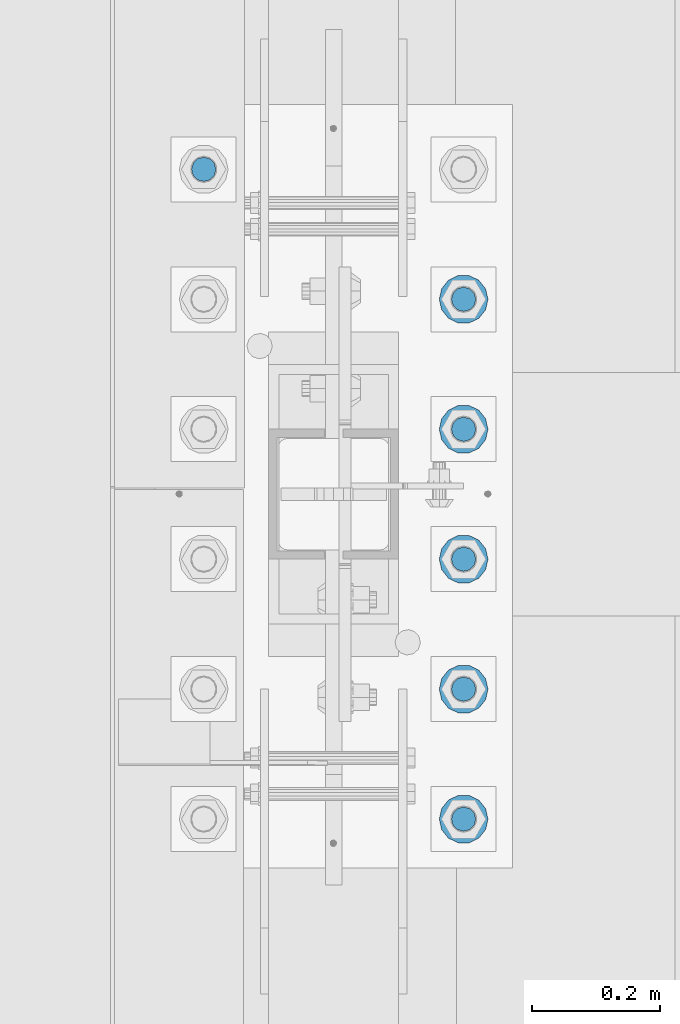
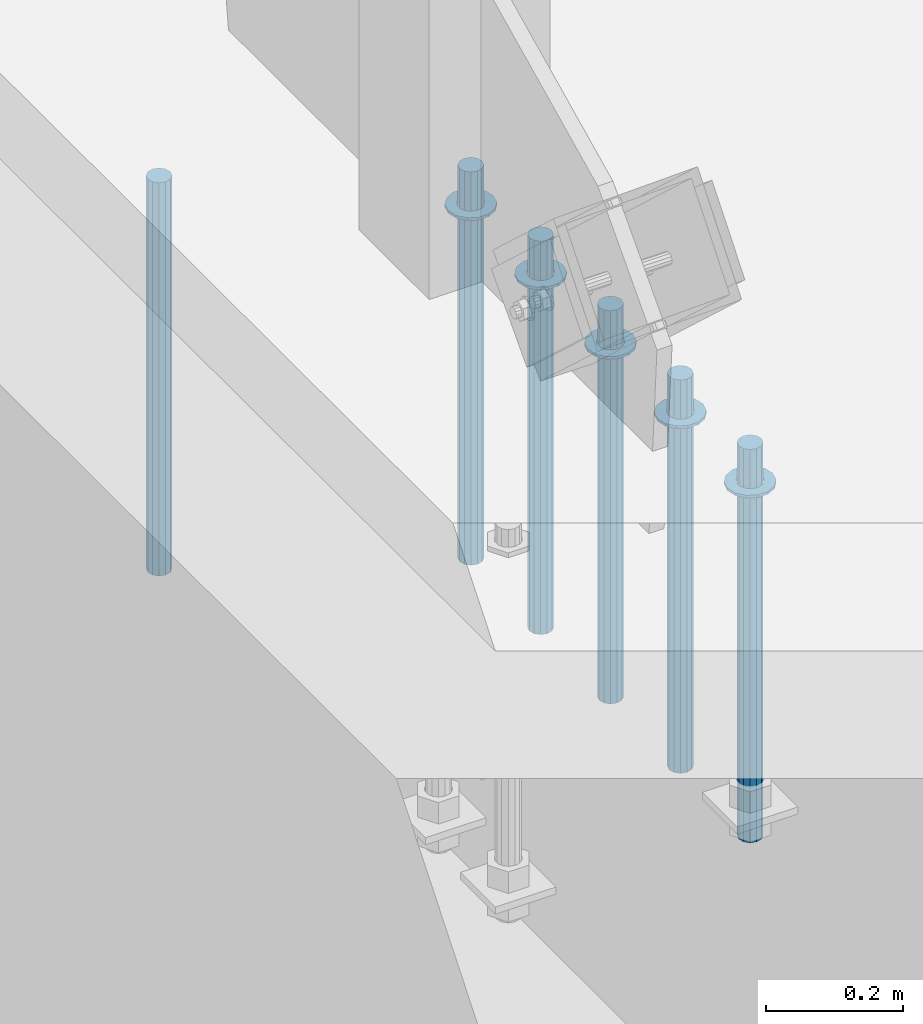
# One storey, part 924 of 1763: 11 columns, 1 element without a shape of its own.
"""IFC2X3 building model written with IfcOpenShell, lengths in millimetres."""

import ifcopenshell
import ifcopenshell.guid

model = None  # the IFC model being written
_history = None  # IfcOwnerHistory: only IFC2X3 demands one
_inside = {}  # id of a spatial element -> (the spatial element, [elements in it])
_under = {}  # id of a project, library or spatial element -> (it, [spatial elements below it])
_declared = {}  # id of a project -> (the project, [libraries it declares])
_typed = {}  # id of a type object -> (the type object, [elements of that type])
_made_of = {}  # id of a material, layer set ... -> (it, [elements and type objects made of it])


def new_model(schema):
    """Start an empty IFC model of exactly this schema.

    Asked for "IFC4X3", IfcOpenShell would pick the latest addendum, in which some entities
    have other attributes; the version numbers below select the first issue.
    IFC2X3 requires an IfcOwnerHistory on every rooted entity: one is made here for all.
    """
    global model, _history
    if schema == "IFC4X3":
        model = ifcopenshell.file(schema_version=(4, 3, 0, 0))
    else:
        model = ifcopenshell.file(schema=schema)
    _inside.clear()
    _under.clear()
    _declared.clear()
    _typed.clear()
    _made_of.clear()
    _history = None
    if model.schema == "IFC2X3":
        org = make("IfcOrganization", Name="unknown")
        user = make(
            "IfcPersonAndOrganization",
            ThePerson=make("IfcPerson", FamilyName="unknown"),
            TheOrganization=org,
        )
        app = make(
            "IfcApplication",
            ApplicationDeveloper=org,
            Version="unknown",
            ApplicationFullName="unknown",
            ApplicationIdentifier="unknown",
        )
        _history = make(
            "IfcOwnerHistory",
            OwningUser=user,
            OwningApplication=app,
            ChangeAction="ADDED",
            CreationDate=0,
        )
    return model


def make(cls, **values):
    """One entity of the class cls with the attributes given. An attribute that is None is left unset."""
    return model.create_entity(
        cls, **{name: value for name, value in values.items() if value is not None}
    )


def rooted(cls, **values):
    """An entity with a GlobalId (a new one), such as an element, a storey or a relation."""
    return make(cls, GlobalId=ifcopenshell.guid.new(), OwnerHistory=_history, **values)


def si_unit(unit_type, name, prefix=None):
    """IfcSIUnit, for example si_unit("LENGTHUNIT", "METRE", prefix="MILLI")."""
    return make("IfcSIUnit", UnitType=unit_type, Prefix=prefix, Name=name)


def assignment(units):
    """IfcUnitAssignment: the units of a project."""
    return None if units is None else make("IfcUnitAssignment", Units=units)


def point(xyz):
    """IfcCartesianPoint."""
    return None if xyz is None else make("IfcCartesianPoint", Coordinates=xyz)


def direction(xyz):
    """IfcDirection."""
    return None if xyz is None else make("IfcDirection", DirectionRatios=xyz)


def frame(location, z_axis=None, x_axis=None):
    """IfcAxis2Placement3D, a coordinate frame: its origin and axes. An axis left out is left unset."""
    return make(
        "IfcAxis2Placement3D",
        Location=point(location),
        Axis=direction(z_axis),
        RefDirection=direction(x_axis),
    )


def origin_with_axes():
    """The frame at (0, 0, 0) with the z axis (0, 0, 1) and the x axis (1, 0, 0) written out."""
    return frame((0.0, 0.0, 0.0), z_axis=(0.0, 0.0, 1.0), x_axis=(1.0, 0.0, 0.0))


def place(relative_to, where):
    """IfcLocalPlacement: puts the frame where relative to a parent placement (None: the world)."""
    return make(
        "IfcLocalPlacement", PlacementRelTo=relative_to, RelativePlacement=where
    )


def context(
    kind, dimensions, precision=None, world=None, true_north=None, identifier=None
):
    """IfcGeometricRepresentationContext, for example the 3D "Model" context."""
    return make(
        "IfcGeometricRepresentationContext",
        ContextIdentifier=identifier,
        ContextType=kind,
        CoordinateSpaceDimension=dimensions,
        Precision=precision,
        WorldCoordinateSystem=world,
        TrueNorth=true_north,
    )


def subcontext(parent, identifier, kind, view, scale=None):
    """IfcGeometricRepresentationSubContext, for example "Body" below "Model"."""
    return make(
        "IfcGeometricRepresentationSubContext",
        ContextIdentifier=identifier,
        ContextType=kind,
        ParentContext=parent,
        TargetScale=scale,
        TargetView=view,
    )


def project(units=None, contexts=None):
    """IfcProject with its units and contexts."""
    return rooted(
        "IfcProject",
        Name="project",
        RepresentationContexts=contexts,
        UnitsInContext=assignment(units),
    )


def spatial(cls, under=None, at=None, **own):
    """A site, building, storey or space (cls), placed at a placement, below another one or the project."""
    s = rooted(cls, ObjectPlacement=at, **own)
    if under is not None:
        _under.setdefault(under.id(), (under, []))[1].append(s)
    return s


def faces_of(points, faces, orient=None, outer=None):
    """IfcFace entities. A face is a list of loops; a loop is a list of indices into points, from 0.

    orient and outer hold one flag for each loop. By default every Orientation is true, the
    first loop of a face is its IfcFaceOuterBound and the others are IfcFaceBound.
    """
    made = []
    for i, loops in enumerate(faces):
        bounds = []
        for j, loop in enumerate(loops):
            is_outer = j == 0 if outer is None else outer[i][j]
            bounds.append(
                make(
                    "IfcFaceOuterBound" if is_outer else "IfcFaceBound",
                    Bound=make("IfcPolyLoop", Polygon=[points[k] for k in loop]),
                    Orientation=True if orient is None else orient[i][j],
                )
            )
        made.append(make("IfcFace", Bounds=bounds))
    return made


def faceted_brep(points, faces, orient=None, outer=None, voids=None):
    """IfcFacetedBrep: a solid bounded by flat faces; with voids (closed shells), ...WithVoids."""
    shared = [point(p) for p in points]
    hull = make("IfcClosedShell", CfsFaces=faces_of(shared, faces, orient, outer))
    if voids is None:
        return make("IfcFacetedBrep", Outer=hull)
    return make(
        "IfcFacetedBrepWithVoids",
        Outer=hull,
        Voids=[
            make(cls, CfsFaces=faces_of(shared, fs, o, b)) for cls, fs, o, b in voids
        ],
    )


def shape(context_of_items, identifier, shape_type, items):
    """IfcShapeRepresentation: the items that make up one representation, for example the "Body"."""
    return make(
        "IfcShapeRepresentation",
        ContextOfItems=context_of_items,
        RepresentationIdentifier=identifier,
        RepresentationType=shape_type,
        Items=items,
    )


def material(Name=None, Category=None):
    """IfcMaterial."""
    return make("IfcMaterial", Name=Name, Category=Category)


def made_of(thing, what):
    """Note that an element or type object is made of a material, layer set ...; save() writes the relation."""
    if what is not None:
        _made_of.setdefault(what.id(), (what, []))[1].append(thing)
    return thing


def type_object(cls, material=None, **own):
    """A type object (cls), such as IfcWallType, which elements share."""
    return made_of(rooted(cls, **own), material)


def element(
    cls,
    number,
    at=None,
    inside=None,
    cuts=None,
    type_object=None,
    material=None,
    context=None,
    identifier="Body",
    shape_type=None,
    held_by="IfcProductDefinitionShape",
    body=None,
    shapes=None,
    **own,
):
    """One element of the class cls, such as IfcWall. Its Tag is "e" and its number.

    at: its placement. inside: the storey or other place that contains it. cuts: it is an
    opening in that element (IfcRelVoidsElement). A single representation is given by context,
    identifier, shape_type and body (its items); several are given by shapes. held_by: the class
    of the entity that holds the representations. save() writes the other relations.
    """
    e = rooted(cls, Tag="e%d" % number, ObjectPlacement=at, **own)
    if body is not None:
        shapes = [shape(context, identifier, shape_type, body)]
    if shapes is not None:
        e.Representation = make(held_by, Representations=shapes)
    if inside is not None:
        _inside.setdefault(inside.id(), (inside, []))[1].append(e)
    if cuts is not None:
        rooted(
            "IfcRelVoidsElement", RelatingBuildingElement=cuts, RelatedOpeningElement=e
        )
    if type_object is not None:
        _typed.setdefault(type_object.id(), (type_object, []))[1].append(e)
    return made_of(e, material)


def aggregate(whole, parts):
    """IfcRelAggregates: a whole, such as a stair, and the parts it consists of."""
    return rooted("IfcRelAggregates", RelatingObject=whole, RelatedObjects=parts)


def save(model, path):
    """Write the relations noted so far, then the file.

    IfcRelAggregates (storeys below a building ...), IfcRelContainedInSpatialStructure (elements
    in a storey), IfcRelDefinesByType, IfcRelAssociatesMaterial and IfcRelDeclares: one each for
    every whole, place, type object, material and project.
    """
    for whole, parts in _under.values():
        aggregate(whole, parts)
    for where, things in _inside.values():
        rooted(
            "IfcRelContainedInSpatialStructure",
            RelatedElements=things,
            RelatingStructure=where,
        )
    for kind, things in _typed.values():
        rooted("IfcRelDefinesByType", RelatedObjects=things, RelatingType=kind)
    for what, things in _made_of.values():
        rooted("IfcRelAssociatesMaterial", RelatedObjects=things, RelatingMaterial=what)
    for by, libraries in _declared.values():
        rooted("IfcRelDeclares", RelatingContext=by, RelatedDefinitions=libraries)
    model.write(path)


model = new_model("IFC2X3")

# Units and contexts
model_context = context("Model", 3, precision=1e-05, world=origin_with_axes())
body_context = subcontext(model_context, "Body", "Model", "MODEL_VIEW")
ifc_project = project(units=[si_unit("LENGTHUNIT", "METRE", prefix="MILLI"), si_unit("AREAUNIT", "SQUARE_METRE"), si_unit("VOLUMEUNIT", "CUBIC_METRE"), si_unit("MASSUNIT", "GRAM", prefix="KILO"), si_unit("TIMEUNIT", "SECOND"), si_unit("PLANEANGLEUNIT", "RADIAN"), si_unit("SOLIDANGLEUNIT", "STERADIAN"), si_unit("THERMODYNAMICTEMPERATUREUNIT", "DEGREE_CELSIUS"), si_unit("LUMINOUSINTENSITYUNIT", "LUMEN")], contexts=[model_context])

# Site, building, storey
site_placement = place(None, origin_with_axes())
site = spatial("IfcSite", under=ifc_project, at=site_placement, CompositionType="ELEMENT")
building_placement = place(site_placement, origin_with_axes())
building = spatial("IfcBuilding", under=site, at=building_placement, Name="Undefined", CompositionType="ELEMENT")
storey_placement = place(building_placement, origin_with_axes())
storey = spatial("IfcBuildingStorey", under=building, at=storey_placement, Name="Undefined", CompositionType="ELEMENT", Elevation=0.0)

# Assembly, columns
assembly_placement = place(storey_placement, origin_with_axes())
assembly = element("IfcElementAssembly", 1, at=assembly_placement, inside=storey, Name="TEMPLATE", AssemblyPlace="NOTDEFINED", PredefinedType="RIGID_FRAME")
ifc_material_1 = material(Name="STEEL/F436")
column_type_1 = type_object("IfcColumnType", Name="1-1/2_WASHER", PredefinedType="NOTDEFINED")
column_1_placement = place(assembly_placement, frame((-87172.2372736984, -50.7999999999992, 5151.4375), z_axis=(0.0, 1.0, 0.0), x_axis=(0.0, 0.0, -1.0)))
column_1 = element("IfcColumn", 2, at=column_1_placement, type_object=column_type_1, material=ifc_material_1, Name="WASHER", ObjectType="1-1/2_WASHER", context=body_context, shape_type="Brep", body=[
    faceted_brep([(0.0, -38.0999984741211, 0.0), (0.0, -34.3269124923099, -16.5309697983248), (4.76249999999982, -34.3269124923099, -16.5309697983248), (4.76249999999982, -38.0999984741211, 0.0), (0.0, -23.7549604994492, -29.7877782890519), (4.76249999999982, -23.7549604994492, -29.7877782890519), (0.0, -8.47804724419257, -37.1447519665053), (4.76249999999982, -8.47804724419257, -37.1447519665053), (0.0, 8.47804724419257, -37.1447519665053), (4.76249999999982, 8.47804724419257, -37.1447519665053), (0.0, 23.7549604994492, -29.7877782890519), (4.76249999999982, 23.7549604994492, -29.7877782890519), (0.0, 34.3269124923099, -16.5309697983248), (4.76249999999982, 34.3269124923099, -16.5309697983248), (0.0, 38.0999984741211, 0.0), (4.76249999999982, 38.0999984741211, 0.0), (0.0, 34.3269124923099, 16.5309697983248), (4.76249999999982, 34.3269124923099, 16.5309697983248), (0.0, 23.7549604994492, 29.7877782890519), (4.76249999999982, 23.7549604994492, 29.7877782890519), (0.0, 8.47804724419257, 37.1447519665053), (4.76249999999982, 8.47804724419257, 37.1447519665053), (0.0, -8.47804724419257, 37.1447519665053), (4.76249999999982, -8.47804724419257, 37.1447519665053), (0.0, -23.7549604994492, 29.7877782890519), (4.76249999999982, -23.7549604994492, 29.7877782890519), (0.0, -34.3269124923099, 16.5309697983248), (4.76249999999982, -34.3269124923099, 16.5309697983248), (0.0, 0.0, 20.6399993896484), (0.0, 8.95536011056538, 18.5959968835978), (4.76249999999982, 8.95536011056538, 18.5959968835978), (4.76249999999982, 0.0, 20.6399993896484), (0.0, 16.1370013209453, 12.8688291298167), (4.76249999999982, 16.1370013209453, 12.8688291298167), (0.0, 20.1225115123816, 4.59283194104137), (4.76249999999982, 20.1225115123816, 4.59283194104137), (0.0, 20.1225115123816, -4.59283194104319), (4.76249999999982, 20.1225115123816, -4.59283194104319), (0.0, 16.1370013209453, -12.8688291298167), (4.76249999999982, 16.1370013209453, -12.8688291298167), (0.0, 8.95536011056538, -18.5959968835978), (4.76249999999982, 8.95536011056538, -18.5959968835978), (0.0, 0.0, -20.6399993896484), (4.76249999999982, 0.0, -20.6399993896484), (0.0, -8.95536011056538, -18.5959968835978), (4.76249999999982, -8.95536011056538, -18.5959968835978), (0.0, -16.1370013209453, -12.8688291298167), (4.76249999999982, -16.1370013209453, -12.8688291298167), (0.0, -20.1225115123816, -4.59283194104137), (4.76249999999982, -20.1225115123816, -4.59283194104137), (0.0, -20.1225115123816, 4.59283194104319), (4.76249999999982, -20.1225115123816, 4.59283194104319), (0.0, -16.1370013209453, 12.8688291298167), (4.76249999999982, -16.1370013209453, 12.8688291298167), (0.0, -8.95536011056538, 18.5959968835978), (4.76249999999982, -8.95536011056538, 18.5959968835978)], [[[0, 1, 2, 3]], [[1, 4, 5, 2]], [[4, 6, 7, 5]], [[6, 8, 9, 7]], [[8, 10, 11, 9]], [[10, 12, 13, 11]], [[12, 14, 15, 13]], [[14, 16, 17, 15]], [[16, 18, 19, 17]], [[18, 20, 21, 19]], [[20, 22, 23, 21]], [[22, 24, 25, 23]], [[24, 26, 27, 25]], [[26, 0, 3, 27]], [[28, 29, 30, 31]], [[29, 32, 33, 30]], [[32, 34, 35, 33]], [[34, 36, 37, 35]], [[36, 38, 39, 37]], [[38, 40, 41, 39]], [[40, 42, 43, 41]], [[42, 44, 45, 43]], [[44, 46, 47, 45]], [[46, 48, 49, 47]], [[48, 50, 51, 49]], [[50, 52, 53, 51]], [[52, 54, 55, 53]], [[54, 28, 31, 55]], [[5, 7, 9, 11, 13, 15, 17, 19, 21, 23, 25, 27, 3, 2], [33, 35, 37, 39, 41, 43, 45, 47, 49, 51, 53, 55, 31, 30]], [[26, 24, 22, 20, 18, 16, 14, 12, 10, 8, 6, 4, 1, 0], [54, 52, 50, 48, 46, 44, 42, 40, 38, 36, 34, 32, 29, 28]]]),
])
column_2_placement = place(assembly_placement, frame((-87172.2372736984, 152.400000000001, 5151.4375), z_axis=(0.0, 1.0, 0.0), x_axis=(0.0, 0.0, -1.0)))
column_2 = element("IfcColumn", 3, at=column_2_placement, type_object=column_type_1, material=ifc_material_1, Name="WASHER", ObjectType="1-1/2_WASHER", context=body_context, shape_type="Brep", body=[
    faceted_brep([(0.0, -38.0999984741211, 0.0), (0.0, -34.3269124923099, -16.5309697983248), (4.76249999999982, -34.3269124923099, -16.5309697983248), (4.76249999999982, -38.0999984741211, 0.0), (0.0, -23.7549604994492, -29.7877782890519), (4.76249999999982, -23.7549604994492, -29.7877782890519), (0.0, -8.47804724419257, -37.1447519665053), (4.76249999999982, -8.47804724419257, -37.1447519665053), (0.0, 8.47804724419257, -37.1447519665053), (4.76249999999982, 8.47804724419257, -37.1447519665053), (0.0, 23.7549604994492, -29.7877782890519), (4.76249999999982, 23.7549604994492, -29.7877782890519), (0.0, 34.3269124923099, -16.5309697983248), (4.76249999999982, 34.3269124923099, -16.5309697983248), (0.0, 38.0999984741211, 0.0), (4.76249999999982, 38.0999984741211, 0.0), (0.0, 34.3269124923099, 16.5309697983248), (4.76249999999982, 34.3269124923099, 16.5309697983248), (0.0, 23.7549604994492, 29.7877782890519), (4.76249999999982, 23.7549604994492, 29.7877782890519), (0.0, 8.47804724419257, 37.1447519665053), (4.76249999999982, 8.47804724419257, 37.1447519665053), (0.0, -8.47804724419257, 37.1447519665053), (4.76249999999982, -8.47804724419257, 37.1447519665053), (0.0, -23.7549604994492, 29.7877782890519), (4.76249999999982, -23.7549604994492, 29.7877782890519), (0.0, -34.3269124923099, 16.5309697983248), (4.76249999999982, -34.3269124923099, 16.5309697983248), (0.0, 0.0, 20.6399993896484), (0.0, 8.95536011056538, 18.5959968835978), (4.76249999999982, 8.95536011056538, 18.5959968835978), (4.76249999999982, 0.0, 20.6399993896484), (0.0, 16.1370013209453, 12.8688291298167), (4.76249999999982, 16.1370013209453, 12.8688291298167), (0.0, 20.1225115123816, 4.59283194104137), (4.76249999999982, 20.1225115123816, 4.59283194104137), (0.0, 20.1225115123816, -4.59283194104319), (4.76249999999982, 20.1225115123816, -4.59283194104319), (0.0, 16.1370013209453, -12.8688291298167), (4.76249999999982, 16.1370013209453, -12.8688291298167), (0.0, 8.95536011056538, -18.5959968835978), (4.76249999999982, 8.95536011056538, -18.5959968835978), (0.0, 0.0, -20.6399993896484), (4.76249999999982, 0.0, -20.6399993896484), (0.0, -8.95536011056538, -18.5959968835978), (4.76249999999982, -8.95536011056538, -18.5959968835978), (0.0, -16.1370013209453, -12.8688291298167), (4.76249999999982, -16.1370013209453, -12.8688291298167), (0.0, -20.1225115123816, -4.59283194104137), (4.76249999999982, -20.1225115123816, -4.59283194104137), (0.0, -20.1225115123816, 4.59283194104319), (4.76249999999982, -20.1225115123816, 4.59283194104319), (0.0, -16.1370013209453, 12.8688291298167), (4.76249999999982, -16.1370013209453, 12.8688291298167), (0.0, -8.95536011056538, 18.5959968835978), (4.76249999999982, -8.95536011056538, 18.5959968835978)], [[[0, 1, 2, 3]], [[1, 4, 5, 2]], [[4, 6, 7, 5]], [[6, 8, 9, 7]], [[8, 10, 11, 9]], [[10, 12, 13, 11]], [[12, 14, 15, 13]], [[14, 16, 17, 15]], [[16, 18, 19, 17]], [[18, 20, 21, 19]], [[20, 22, 23, 21]], [[22, 24, 25, 23]], [[24, 26, 27, 25]], [[26, 0, 3, 27]], [[28, 29, 30, 31]], [[29, 32, 33, 30]], [[32, 34, 35, 33]], [[34, 36, 37, 35]], [[36, 38, 39, 37]], [[38, 40, 41, 39]], [[40, 42, 43, 41]], [[42, 44, 45, 43]], [[44, 46, 47, 45]], [[46, 48, 49, 47]], [[48, 50, 51, 49]], [[50, 52, 53, 51]], [[52, 54, 55, 53]], [[54, 28, 31, 55]], [[5, 7, 9, 11, 13, 15, 17, 19, 21, 23, 25, 27, 3, 2], [33, 35, 37, 39, 41, 43, 45, 47, 49, 51, 53, 55, 31, 30]], [[26, 24, 22, 20, 18, 16, 14, 12, 10, 8, 6, 4, 1, 0], [54, 52, 50, 48, 46, 44, 42, 40, 38, 36, 34, 32, 29, 28]]]),
])
column_3_placement = place(assembly_placement, frame((-87172.2372736984, 355.600000000001, 5151.4375), z_axis=(0.0, 1.0, 0.0), x_axis=(0.0, 0.0, -1.0)))
column_3 = element("IfcColumn", 4, at=column_3_placement, type_object=column_type_1, material=ifc_material_1, Name="WASHER", ObjectType="1-1/2_WASHER", context=body_context, shape_type="Brep", body=[
    faceted_brep([(0.0, -38.0999984741211, 0.0), (0.0, -34.3269124923099, -16.5309697983248), (4.76249999999982, -34.3269124923099, -16.5309697983248), (4.76249999999982, -38.0999984741211, 0.0), (0.0, -23.7549604994492, -29.7877782890519), (4.76249999999982, -23.7549604994492, -29.7877782890519), (0.0, -8.47804724419257, -37.1447519665053), (4.76249999999982, -8.47804724419257, -37.1447519665053), (0.0, 8.47804724419257, -37.1447519665053), (4.76249999999982, 8.47804724419257, -37.1447519665053), (0.0, 23.7549604994492, -29.7877782890519), (4.76249999999982, 23.7549604994492, -29.7877782890519), (0.0, 34.3269124923099, -16.5309697983248), (4.76249999999982, 34.3269124923099, -16.5309697983248), (0.0, 38.0999984741211, 0.0), (4.76249999999982, 38.0999984741211, 0.0), (0.0, 34.3269124923099, 16.5309697983248), (4.76249999999982, 34.3269124923099, 16.5309697983248), (0.0, 23.7549604994492, 29.7877782890519), (4.76249999999982, 23.7549604994492, 29.7877782890519), (0.0, 8.47804724419257, 37.1447519665053), (4.76249999999982, 8.47804724419257, 37.1447519665053), (0.0, -8.47804724419257, 37.1447519665053), (4.76249999999982, -8.47804724419257, 37.1447519665053), (0.0, -23.7549604994492, 29.7877782890519), (4.76249999999982, -23.7549604994492, 29.7877782890519), (0.0, -34.3269124923099, 16.5309697983248), (4.76249999999982, -34.3269124923099, 16.5309697983248), (0.0, 0.0, 20.6399993896484), (0.0, 8.95536011056538, 18.5959968835978), (4.76249999999982, 8.95536011056538, 18.5959968835978), (4.76249999999982, 0.0, 20.6399993896484), (0.0, 16.1370013209453, 12.8688291298167), (4.76249999999982, 16.1370013209453, 12.8688291298167), (0.0, 20.1225115123816, 4.59283194104137), (4.76249999999982, 20.1225115123816, 4.59283194104137), (0.0, 20.1225115123816, -4.59283194104319), (4.76249999999982, 20.1225115123816, -4.59283194104319), (0.0, 16.1370013209453, -12.8688291298167), (4.76249999999982, 16.1370013209453, -12.8688291298167), (0.0, 8.95536011056538, -18.5959968835978), (4.76249999999982, 8.95536011056538, -18.5959968835978), (0.0, 0.0, -20.6399993896484), (4.76249999999982, 0.0, -20.6399993896484), (0.0, -8.95536011056538, -18.5959968835978), (4.76249999999982, -8.95536011056538, -18.5959968835978), (0.0, -16.1370013209453, -12.8688291298167), (4.76249999999982, -16.1370013209453, -12.8688291298167), (0.0, -20.1225115123816, -4.59283194104137), (4.76249999999982, -20.1225115123816, -4.59283194104137), (0.0, -20.1225115123816, 4.59283194104319), (4.76249999999982, -20.1225115123816, 4.59283194104319), (0.0, -16.1370013209453, 12.8688291298167), (4.76249999999982, -16.1370013209453, 12.8688291298167), (0.0, -8.95536011056538, 18.5959968835978), (4.76249999999982, -8.95536011056538, 18.5959968835978)], [[[0, 1, 2, 3]], [[1, 4, 5, 2]], [[4, 6, 7, 5]], [[6, 8, 9, 7]], [[8, 10, 11, 9]], [[10, 12, 13, 11]], [[12, 14, 15, 13]], [[14, 16, 17, 15]], [[16, 18, 19, 17]], [[18, 20, 21, 19]], [[20, 22, 23, 21]], [[22, 24, 25, 23]], [[24, 26, 27, 25]], [[26, 0, 3, 27]], [[28, 29, 30, 31]], [[29, 32, 33, 30]], [[32, 34, 35, 33]], [[34, 36, 37, 35]], [[36, 38, 39, 37]], [[38, 40, 41, 39]], [[40, 42, 43, 41]], [[42, 44, 45, 43]], [[44, 46, 47, 45]], [[46, 48, 49, 47]], [[48, 50, 51, 49]], [[50, 52, 53, 51]], [[52, 54, 55, 53]], [[54, 28, 31, 55]], [[5, 7, 9, 11, 13, 15, 17, 19, 21, 23, 25, 27, 3, 2], [33, 35, 37, 39, 41, 43, 45, 47, 49, 51, 53, 55, 31, 30]], [[26, 24, 22, 20, 18, 16, 14, 12, 10, 8, 6, 4, 1, 0], [54, 52, 50, 48, 46, 44, 42, 40, 38, 36, 34, 32, 29, 28]]]),
])
column_4_placement = place(assembly_placement, frame((-87172.2372736984, 558.800000000001, 5151.4375), z_axis=(0.0, 1.0, 0.0), x_axis=(0.0, 0.0, -1.0)))
column_4 = element("IfcColumn", 5, at=column_4_placement, type_object=column_type_1, material=ifc_material_1, Name="WASHER", ObjectType="1-1/2_WASHER", context=body_context, shape_type="Brep", body=[
    faceted_brep([(0.0, -38.0999984741211, 0.0), (0.0, -34.3269124923099, -16.5309697983248), (4.76249999999982, -34.3269124923099, -16.5309697983248), (4.76249999999982, -38.0999984741211, 0.0), (0.0, -23.7549604994492, -29.7877782890519), (4.76249999999982, -23.7549604994492, -29.7877782890519), (0.0, -8.47804724419257, -37.1447519665053), (4.76249999999982, -8.47804724419257, -37.1447519665053), (0.0, 8.47804724419257, -37.1447519665053), (4.76249999999982, 8.47804724419257, -37.1447519665053), (0.0, 23.7549604994492, -29.7877782890519), (4.76249999999982, 23.7549604994492, -29.7877782890519), (0.0, 34.3269124923099, -16.5309697983248), (4.76249999999982, 34.3269124923099, -16.5309697983248), (0.0, 38.0999984741211, 0.0), (4.76249999999982, 38.0999984741211, 0.0), (0.0, 34.3269124923099, 16.5309697983248), (4.76249999999982, 34.3269124923099, 16.5309697983248), (0.0, 23.7549604994492, 29.7877782890519), (4.76249999999982, 23.7549604994492, 29.7877782890519), (0.0, 8.47804724419257, 37.1447519665053), (4.76249999999982, 8.47804724419257, 37.1447519665053), (0.0, -8.47804724419257, 37.1447519665053), (4.76249999999982, -8.47804724419257, 37.1447519665053), (0.0, -23.7549604994492, 29.7877782890519), (4.76249999999982, -23.7549604994492, 29.7877782890519), (0.0, -34.3269124923099, 16.5309697983248), (4.76249999999982, -34.3269124923099, 16.5309697983248), (0.0, 0.0, 20.6399993896484), (0.0, 8.95536011056538, 18.5959968835978), (4.76249999999982, 8.95536011056538, 18.5959968835978), (4.76249999999982, 0.0, 20.6399993896484), (0.0, 16.1370013209453, 12.8688291298167), (4.76249999999982, 16.1370013209453, 12.8688291298167), (0.0, 20.1225115123816, 4.59283194104137), (4.76249999999982, 20.1225115123816, 4.59283194104137), (0.0, 20.1225115123816, -4.59283194104319), (4.76249999999982, 20.1225115123816, -4.59283194104319), (0.0, 16.1370013209453, -12.8688291298167), (4.76249999999982, 16.1370013209453, -12.8688291298167), (0.0, 8.95536011056538, -18.5959968835978), (4.76249999999982, 8.95536011056538, -18.5959968835978), (0.0, 0.0, -20.6399993896484), (4.76249999999982, 0.0, -20.6399993896484), (0.0, -8.95536011056538, -18.5959968835978), (4.76249999999982, -8.95536011056538, -18.5959968835978), (0.0, -16.1370013209453, -12.8688291298167), (4.76249999999982, -16.1370013209453, -12.8688291298167), (0.0, -20.1225115123816, -4.59283194104137), (4.76249999999982, -20.1225115123816, -4.59283194104137), (0.0, -20.1225115123816, 4.59283194104319), (4.76249999999982, -20.1225115123816, 4.59283194104319), (0.0, -16.1370013209453, 12.8688291298167), (4.76249999999982, -16.1370013209453, 12.8688291298167), (0.0, -8.95536011056538, 18.5959968835978), (4.76249999999982, -8.95536011056538, 18.5959968835978)], [[[0, 1, 2, 3]], [[1, 4, 5, 2]], [[4, 6, 7, 5]], [[6, 8, 9, 7]], [[8, 10, 11, 9]], [[10, 12, 13, 11]], [[12, 14, 15, 13]], [[14, 16, 17, 15]], [[16, 18, 19, 17]], [[18, 20, 21, 19]], [[20, 22, 23, 21]], [[22, 24, 25, 23]], [[24, 26, 27, 25]], [[26, 0, 3, 27]], [[28, 29, 30, 31]], [[29, 32, 33, 30]], [[32, 34, 35, 33]], [[34, 36, 37, 35]], [[36, 38, 39, 37]], [[38, 40, 41, 39]], [[40, 42, 43, 41]], [[42, 44, 45, 43]], [[44, 46, 47, 45]], [[46, 48, 49, 47]], [[48, 50, 51, 49]], [[50, 52, 53, 51]], [[52, 54, 55, 53]], [[54, 28, 31, 55]], [[5, 7, 9, 11, 13, 15, 17, 19, 21, 23, 25, 27, 3, 2], [33, 35, 37, 39, 41, 43, 45, 47, 49, 51, 53, 55, 31, 30]], [[26, 24, 22, 20, 18, 16, 14, 12, 10, 8, 6, 4, 1, 0], [54, 52, 50, 48, 46, 44, 42, 40, 38, 36, 34, 32, 29, 28]]]),
])
column_5_placement = place(assembly_placement, frame((-87172.2372736984, 762.000000000001, 5151.4375), z_axis=(0.0, 1.0, 0.0), x_axis=(0.0, 0.0, -1.0)))
column_5 = element("IfcColumn", 6, at=column_5_placement, type_object=column_type_1, material=ifc_material_1, Name="WASHER", ObjectType="1-1/2_WASHER", context=body_context, shape_type="Brep", body=[
    faceted_brep([(0.0, -38.0999984741211, 0.0), (0.0, -34.3269124923099, -16.5309697983248), (4.76249999999982, -34.3269124923099, -16.5309697983248), (4.76249999999982, -38.0999984741211, 0.0), (0.0, -23.7549604994492, -29.7877782890519), (4.76249999999982, -23.7549604994492, -29.7877782890519), (0.0, -8.47804724419257, -37.1447519665053), (4.76249999999982, -8.47804724419257, -37.1447519665053), (0.0, 8.47804724419257, -37.1447519665053), (4.76249999999982, 8.47804724419257, -37.1447519665053), (0.0, 23.7549604994492, -29.7877782890519), (4.76249999999982, 23.7549604994492, -29.7877782890519), (0.0, 34.3269124923099, -16.5309697983248), (4.76249999999982, 34.3269124923099, -16.5309697983248), (0.0, 38.0999984741211, 0.0), (4.76249999999982, 38.0999984741211, 0.0), (0.0, 34.3269124923099, 16.5309697983248), (4.76249999999982, 34.3269124923099, 16.5309697983248), (0.0, 23.7549604994492, 29.7877782890519), (4.76249999999982, 23.7549604994492, 29.7877782890519), (0.0, 8.47804724419257, 37.1447519665053), (4.76249999999982, 8.47804724419257, 37.1447519665053), (0.0, -8.47804724419257, 37.1447519665053), (4.76249999999982, -8.47804724419257, 37.1447519665053), (0.0, -23.7549604994492, 29.7877782890519), (4.76249999999982, -23.7549604994492, 29.7877782890519), (0.0, -34.3269124923099, 16.5309697983248), (4.76249999999982, -34.3269124923099, 16.5309697983248), (0.0, 0.0, 20.6399993896484), (0.0, 8.95536011056538, 18.5959968835978), (4.76249999999982, 8.95536011056538, 18.5959968835978), (4.76249999999982, 0.0, 20.6399993896484), (0.0, 16.1370013209453, 12.8688291298167), (4.76249999999982, 16.1370013209453, 12.8688291298167), (0.0, 20.1225115123816, 4.59283194104137), (4.76249999999982, 20.1225115123816, 4.59283194104137), (0.0, 20.1225115123816, -4.59283194104319), (4.76249999999982, 20.1225115123816, -4.59283194104319), (0.0, 16.1370013209453, -12.8688291298167), (4.76249999999982, 16.1370013209453, -12.8688291298167), (0.0, 8.95536011056538, -18.5959968835978), (4.76249999999982, 8.95536011056538, -18.5959968835978), (0.0, 0.0, -20.6399993896484), (4.76249999999982, 0.0, -20.6399993896484), (0.0, -8.95536011056538, -18.5959968835978), (4.76249999999982, -8.95536011056538, -18.5959968835978), (0.0, -16.1370013209453, -12.8688291298167), (4.76249999999982, -16.1370013209453, -12.8688291298167), (0.0, -20.1225115123816, -4.59283194104137), (4.76249999999982, -20.1225115123816, -4.59283194104137), (0.0, -20.1225115123816, 4.59283194104319), (4.76249999999982, -20.1225115123816, 4.59283194104319), (0.0, -16.1370013209453, 12.8688291298167), (4.76249999999982, -16.1370013209453, 12.8688291298167), (0.0, -8.95536011056538, 18.5959968835978), (4.76249999999982, -8.95536011056538, 18.5959968835978)], [[[0, 1, 2, 3]], [[1, 4, 5, 2]], [[4, 6, 7, 5]], [[6, 8, 9, 7]], [[8, 10, 11, 9]], [[10, 12, 13, 11]], [[12, 14, 15, 13]], [[14, 16, 17, 15]], [[16, 18, 19, 17]], [[18, 20, 21, 19]], [[20, 22, 23, 21]], [[22, 24, 25, 23]], [[24, 26, 27, 25]], [[26, 0, 3, 27]], [[28, 29, 30, 31]], [[29, 32, 33, 30]], [[32, 34, 35, 33]], [[34, 36, 37, 35]], [[36, 38, 39, 37]], [[38, 40, 41, 39]], [[40, 42, 43, 41]], [[42, 44, 45, 43]], [[44, 46, 47, 45]], [[46, 48, 49, 47]], [[48, 50, 51, 49]], [[50, 52, 53, 51]], [[52, 54, 55, 53]], [[54, 28, 31, 55]], [[5, 7, 9, 11, 13, 15, 17, 19, 21, 23, 25, 27, 3, 2], [33, 35, 37, 39, 41, 43, 45, 47, 49, 51, 53, 55, 31, 30]], [[26, 24, 22, 20, 18, 16, 14, 12, 10, 8, 6, 4, 1, 0], [54, 52, 50, 48, 46, 44, 42, 40, 38, 36, 34, 32, 29, 28]]]),
])
ifc_material_2 = material(Name="STEEL/F1554-GR.55")
column_type_2 = type_object("IfcColumnType", PredefinedType="NOTDEFINED")
column_6_placement = place(assembly_placement, frame((-87172.2372736984, -50.7999999999992, 5219.7), z_axis=(0.0, 1.0, 0.0), x_axis=(0.0, 0.0, -1.0)))
column_6 = element("IfcColumn", 7, at=column_6_placement, type_object=column_type_2, material=ifc_material_2, Name="ALL THREADED ROD", context=body_context, shape_type="Brep", body=[
    faceted_brep([(0.0, -19.0500000000029, 0.0), (0.0, -16.4977839420899, -9.52500000000146), (698.499, -16.4977839420972, -9.52499999999964), (698.499, -19.0500000000029, 0.0), (0.0, -9.52499999999418, -16.4977839420935), (698.499, -9.52500000000146, -16.4977839420935), (1.45519152283669e-11, 1.81898940354586e-12, -19.0499999999993), (698.499, 0.0, -19.0499999999993), (0.0, 9.52499999999418, -16.4977839420935), (698.499, 9.52500000000146, -16.4977839420935), (0.0, 16.4977839420899, -9.52500000000146), (698.499, 16.4977839420972, -9.52499999999964), (0.0, 19.0500000000029, 0.0), (698.499, 19.0500000000029, 0.0), (0.0, 16.4977839420899, 9.52500000000146), (698.499, 16.4977839420972, 9.52499999999964), (0.0, 9.52499999999418, 16.4977839420935), (698.499, 9.52500000000146, 16.4977839420935), (1.45519152283669e-11, 1.81898940354586e-12, 19.0499999999993), (698.499, 0.0, 19.0499999999993), (0.0, -9.52499999999418, 16.4977839420935), (698.499, -9.52500000000146, 16.4977839420935), (0.0, -16.4977839420899, 9.52500000000146), (698.499, -16.4977839420972, 9.52499999999964)], [[[0, 1, 2, 3]], [[1, 4, 5, 2]], [[4, 6, 7, 5]], [[6, 8, 9, 7]], [[8, 10, 11, 9]], [[10, 12, 13, 11]], [[12, 14, 15, 13]], [[14, 16, 17, 15]], [[16, 18, 19, 17]], [[18, 20, 21, 19]], [[20, 22, 23, 21]], [[22, 0, 3, 23]], [[5, 7, 9, 11, 13, 15, 17, 19, 21, 23, 3, 2]], [[22, 20, 18, 16, 14, 12, 10, 8, 6, 4, 1, 0]]]),
])
column_7_placement = place(assembly_placement, frame((-87172.2372736984, 152.400000000001, 5219.7), z_axis=(0.0, 1.0, 0.0), x_axis=(0.0, 0.0, -1.0)))
column_7 = element("IfcColumn", 8, at=column_7_placement, type_object=column_type_2, material=ifc_material_2, Name="ALL THREADED ROD", context=body_context, shape_type="Brep", body=[
    faceted_brep([(0.0, -19.0500000000029, 0.0), (0.0, -16.4977839420899, -9.52500000000146), (698.499, -16.4977839420972, -9.52499999999964), (698.499, -19.0500000000029, 0.0), (0.0, -9.52499999999418, -16.4977839420935), (698.499, -9.52500000000146, -16.4977839420935), (1.45519152283669e-11, 1.81898940354586e-12, -19.0499999999993), (698.499, 0.0, -19.0499999999993), (0.0, 9.52499999999418, -16.4977839420935), (698.499, 9.52500000000146, -16.4977839420935), (0.0, 16.4977839420899, -9.52500000000146), (698.499, 16.4977839420972, -9.52499999999964), (0.0, 19.0500000000029, 0.0), (698.499, 19.0500000000029, 0.0), (0.0, 16.4977839420899, 9.52500000000146), (698.499, 16.4977839420972, 9.52499999999964), (0.0, 9.52499999999418, 16.4977839420935), (698.499, 9.52500000000146, 16.4977839420935), (1.45519152283669e-11, 1.81898940354586e-12, 19.0499999999993), (698.499, 0.0, 19.0499999999993), (0.0, -9.52499999999418, 16.4977839420935), (698.499, -9.52500000000146, 16.4977839420935), (0.0, -16.4977839420899, 9.52500000000146), (698.499, -16.4977839420972, 9.52499999999964)], [[[0, 1, 2, 3]], [[1, 4, 5, 2]], [[4, 6, 7, 5]], [[6, 8, 9, 7]], [[8, 10, 11, 9]], [[10, 12, 13, 11]], [[12, 14, 15, 13]], [[14, 16, 17, 15]], [[16, 18, 19, 17]], [[18, 20, 21, 19]], [[20, 22, 23, 21]], [[22, 0, 3, 23]], [[5, 7, 9, 11, 13, 15, 17, 19, 21, 23, 3, 2]], [[22, 20, 18, 16, 14, 12, 10, 8, 6, 4, 1, 0]]]),
])
column_8_placement = place(assembly_placement, frame((-87172.2372736984, 355.600000000001, 5219.7), z_axis=(0.0, 1.0, 0.0), x_axis=(0.0, 0.0, -1.0)))
column_8 = element("IfcColumn", 9, at=column_8_placement, type_object=column_type_2, material=ifc_material_2, Name="ALL THREADED ROD", context=body_context, shape_type="Brep", body=[
    faceted_brep([(0.0, -19.0500000000029, 0.0), (0.0, -16.4977839420899, -9.52500000000146), (698.499, -16.4977839420972, -9.52499999999964), (698.499, -19.0500000000029, 0.0), (0.0, -9.52499999999418, -16.4977839420935), (698.499, -9.52500000000146, -16.4977839420935), (1.45519152283669e-11, 1.81898940354586e-12, -19.0499999999993), (698.499, 0.0, -19.0499999999993), (0.0, 9.52499999999418, -16.4977839420935), (698.499, 9.52500000000146, -16.4977839420935), (0.0, 16.4977839420899, -9.52500000000146), (698.499, 16.4977839420972, -9.52499999999964), (0.0, 19.0500000000029, 0.0), (698.499, 19.0500000000029, 0.0), (0.0, 16.4977839420899, 9.52500000000146), (698.499, 16.4977839420972, 9.52499999999964), (0.0, 9.52499999999418, 16.4977839420935), (698.499, 9.52500000000146, 16.4977839420935), (1.45519152283669e-11, 1.81898940354586e-12, 19.0499999999993), (698.499, 0.0, 19.0499999999993), (0.0, -9.52499999999418, 16.4977839420935), (698.499, -9.52500000000146, 16.4977839420935), (0.0, -16.4977839420899, 9.52500000000146), (698.499, -16.4977839420972, 9.52499999999964)], [[[0, 1, 2, 3]], [[1, 4, 5, 2]], [[4, 6, 7, 5]], [[6, 8, 9, 7]], [[8, 10, 11, 9]], [[10, 12, 13, 11]], [[12, 14, 15, 13]], [[14, 16, 17, 15]], [[16, 18, 19, 17]], [[18, 20, 21, 19]], [[20, 22, 23, 21]], [[22, 0, 3, 23]], [[5, 7, 9, 11, 13, 15, 17, 19, 21, 23, 3, 2]], [[22, 20, 18, 16, 14, 12, 10, 8, 6, 4, 1, 0]]]),
])
column_9_placement = place(assembly_placement, frame((-87172.2372736984, 558.800000000001, 5219.7), z_axis=(0.0, 1.0, 0.0), x_axis=(0.0, 0.0, -1.0)))
column_9 = element("IfcColumn", 10, at=column_9_placement, type_object=column_type_2, material=ifc_material_2, Name="ALL THREADED ROD", context=body_context, shape_type="Brep", body=[
    faceted_brep([(0.0, -19.0500000000029, 0.0), (0.0, -16.4977839420899, -9.52500000000146), (698.499, -16.4977839420972, -9.52499999999964), (698.499, -19.0500000000029, 0.0), (0.0, -9.52499999999418, -16.4977839420935), (698.499, -9.52500000000146, -16.4977839420935), (1.45519152283669e-11, 1.81898940354586e-12, -19.0499999999993), (698.499, 0.0, -19.0499999999993), (0.0, 9.52499999999418, -16.4977839420935), (698.499, 9.52500000000146, -16.4977839420935), (0.0, 16.4977839420899, -9.52500000000146), (698.499, 16.4977839420972, -9.52499999999964), (0.0, 19.0500000000029, 0.0), (698.499, 19.0500000000029, 0.0), (0.0, 16.4977839420899, 9.52500000000146), (698.499, 16.4977839420972, 9.52499999999964), (0.0, 9.52499999999418, 16.4977839420935), (698.499, 9.52500000000146, 16.4977839420935), (1.45519152283669e-11, 1.81898940354586e-12, 19.0499999999993), (698.499, 0.0, 19.0499999999993), (0.0, -9.52499999999418, 16.4977839420935), (698.499, -9.52500000000146, 16.4977839420935), (0.0, -16.4977839420899, 9.52500000000146), (698.499, -16.4977839420972, 9.52499999999964)], [[[0, 1, 2, 3]], [[1, 4, 5, 2]], [[4, 6, 7, 5]], [[6, 8, 9, 7]], [[8, 10, 11, 9]], [[10, 12, 13, 11]], [[12, 14, 15, 13]], [[14, 16, 17, 15]], [[16, 18, 19, 17]], [[18, 20, 21, 19]], [[20, 22, 23, 21]], [[22, 0, 3, 23]], [[5, 7, 9, 11, 13, 15, 17, 19, 21, 23, 3, 2]], [[22, 20, 18, 16, 14, 12, 10, 8, 6, 4, 1, 0]]]),
])
column_10_placement = place(assembly_placement, frame((-87172.2372736984, 762.000000000001, 5219.7), z_axis=(0.0, 1.0, 0.0), x_axis=(0.0, 0.0, -1.0)))
column_10 = element("IfcColumn", 11, at=column_10_placement, type_object=column_type_2, material=ifc_material_2, Name="ALL THREADED ROD", context=body_context, shape_type="Brep", body=[
    faceted_brep([(0.0, -19.0500000000029, 0.0), (0.0, -16.4977839420899, -9.52500000000146), (698.499, -16.4977839420972, -9.52499999999964), (698.499, -19.0500000000029, 0.0), (0.0, -9.52499999999418, -16.4977839420935), (698.499, -9.52500000000146, -16.4977839420935), (1.45519152283669e-11, 1.81898940354586e-12, -19.0499999999993), (698.499, 0.0, -19.0499999999993), (0.0, 9.52499999999418, -16.4977839420935), (698.499, 9.52500000000146, -16.4977839420935), (0.0, 16.4977839420899, -9.52500000000146), (698.499, 16.4977839420972, -9.52499999999964), (0.0, 19.0500000000029, 0.0), (698.499, 19.0500000000029, 0.0), (0.0, 16.4977839420899, 9.52500000000146), (698.499, 16.4977839420972, 9.52499999999964), (0.0, 9.52499999999418, 16.4977839420935), (698.499, 9.52500000000146, 16.4977839420935), (1.45519152283669e-11, 1.81898940354586e-12, 19.0499999999993), (698.499, 0.0, 19.0499999999993), (0.0, -9.52499999999418, 16.4977839420935), (698.499, -9.52500000000146, 16.4977839420935), (0.0, -16.4977839420899, 9.52500000000146), (698.499, -16.4977839420972, 9.52499999999964)], [[[0, 1, 2, 3]], [[1, 4, 5, 2]], [[4, 6, 7, 5]], [[6, 8, 9, 7]], [[8, 10, 11, 9]], [[10, 12, 13, 11]], [[12, 14, 15, 13]], [[14, 16, 17, 15]], [[16, 18, 19, 17]], [[18, 20, 21, 19]], [[20, 22, 23, 21]], [[22, 0, 3, 23]], [[5, 7, 9, 11, 13, 15, 17, 19, 21, 23, 3, 2]], [[22, 20, 18, 16, 14, 12, 10, 8, 6, 4, 1, 0]]]),
])
column_11_placement = place(assembly_placement, frame((-87578.6372736983, 965.200000000001, 5219.7), z_axis=(0.0, -1.0, 0.0), x_axis=(0.0, 0.0, -1.0)))
column_11 = element("IfcColumn", 12, at=column_11_placement, type_object=column_type_2, material=ifc_material_2, Name="ALL THREADED ROD", context=body_context, shape_type="Brep", body=[
    faceted_brep([(0.0, -19.0500000000029, 0.0), (0.0, -16.4977839420899, -9.52500000000146), (698.499, -16.4977839420972, -9.52499999999964), (698.499, -19.0500000000029, 0.0), (0.0, -9.52499999999418, -16.4977839420935), (698.499, -9.52500000000146, -16.4977839420935), (1.45519152283669e-11, 1.81898940354586e-12, -19.0499999999993), (698.499, 0.0, -19.0499999999993), (0.0, 9.52499999999418, -16.4977839420935), (698.499, 9.52500000000146, -16.4977839420935), (0.0, 16.4977839420899, -9.52500000000146), (698.499, 16.4977839420972, -9.52499999999964), (0.0, 19.0500000000029, 0.0), (698.499, 19.0500000000029, 0.0), (0.0, 16.4977839420899, 9.52500000000146), (698.499, 16.4977839420972, 9.52499999999964), (0.0, 9.52499999999418, 16.4977839420935), (698.499, 9.52500000000146, 16.4977839420935), (1.45519152283669e-11, 1.81898940354586e-12, 19.0499999999993), (698.499, 0.0, 19.0499999999993), (0.0, -9.52499999999418, 16.4977839420935), (698.499, -9.52500000000146, 16.4977839420935), (0.0, -16.4977839420899, 9.52500000000146), (698.499, -16.4977839420972, 9.52499999999964)], [[[0, 1, 2, 3]], [[1, 4, 5, 2]], [[4, 6, 7, 5]], [[6, 8, 9, 7]], [[8, 10, 11, 9]], [[10, 12, 13, 11]], [[12, 14, 15, 13]], [[14, 16, 17, 15]], [[16, 18, 19, 17]], [[18, 20, 21, 19]], [[20, 22, 23, 21]], [[22, 0, 3, 23]], [[5, 7, 9, 11, 13, 15, 17, 19, 21, 23, 3, 2]], [[22, 20, 18, 16, 14, 12, 10, 8, 6, 4, 1, 0]]]),
])
aggregate(assembly, [column_1, column_6, column_2, column_7, column_3, column_8, column_4, column_9, column_5, column_10, column_11])

save(model, "model.ifc")
